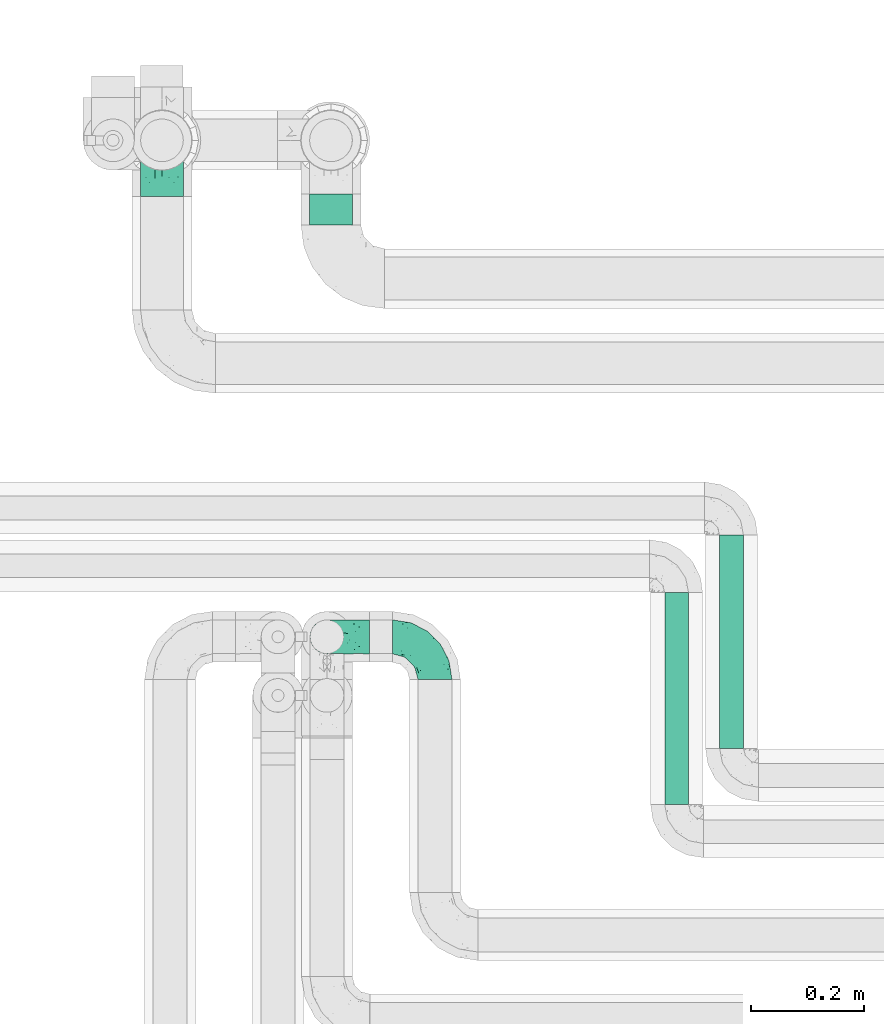
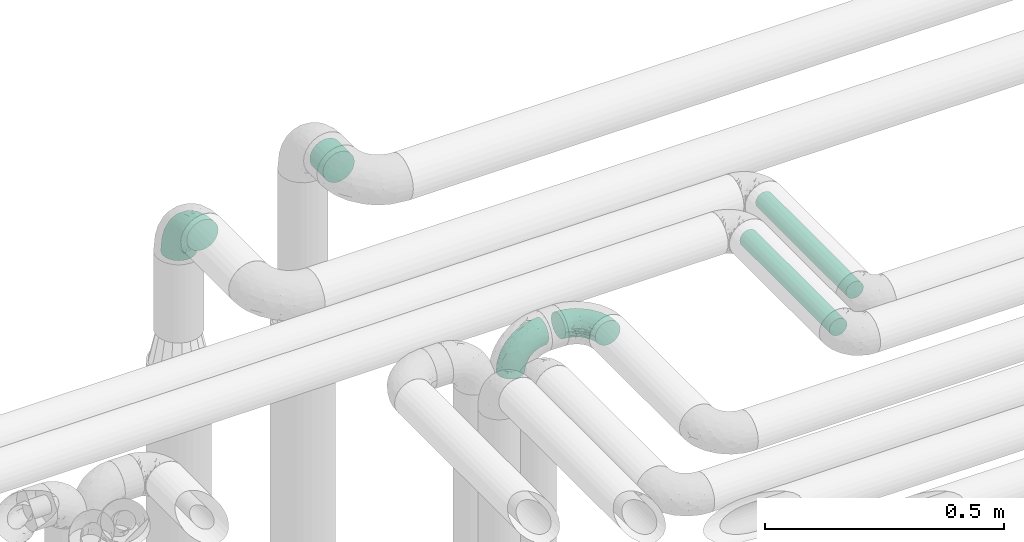
# One storey, part 643 of 827: 3 flow fittings, 3 flow segments.
"""IFC2X3 building model written with IfcOpenShell, lengths in millimetres."""

from ifc_helpers import new_model, entity, si_unit, converted_unit, derived_unit, direction, frame, origin, origin_2d_with_axis, place, context, subcontext, project, spatial, circle, extrude, faceted_brep, source, transform, mapped, material, type_object, type_shapes, element, save


model = new_model("IFC2X3")

# Units and contexts
model_context = context("Model", 3, precision=0.01, world=origin(), true_north=direction((6.12303176911189e-17, 1.0)))
body_context = subcontext(model_context, "Body", "Model", "MODEL_VIEW")
ifc_project = project(units=[si_unit("LENGTHUNIT", "METRE", prefix="MILLI"), si_unit("AREAUNIT", "SQUARE_METRE"), si_unit("VOLUMEUNIT", "CUBIC_METRE"), converted_unit("PLANEANGLEUNIT", "DEGREE", entity("IfcRatioMeasure", 0.0174532925199433), si_unit("PLANEANGLEUNIT", "RADIAN"), dimensions=[0, 0, 0, 0, 0, 0, 0]), si_unit("MASSUNIT", "GRAM", prefix="KILO"), derived_unit("MASSDENSITYUNIT", [(si_unit("MASSUNIT", "GRAM", prefix="KILO"), 1), (si_unit("LENGTHUNIT", "METRE"), -3)]), derived_unit("MOMENTOFINERTIAUNIT", [(si_unit("LENGTHUNIT", "METRE"), 4)]), si_unit("TIMEUNIT", "SECOND"), si_unit("FREQUENCYUNIT", "HERTZ"), si_unit("THERMODYNAMICTEMPERATUREUNIT", "DEGREE_CELSIUS"), derived_unit("THERMALTRANSMITTANCEUNIT", [(si_unit("MASSUNIT", "GRAM", prefix="KILO"), 1), (si_unit("THERMODYNAMICTEMPERATUREUNIT", "KELVIN"), -1), (si_unit("TIMEUNIT", "SECOND"), -3)]), derived_unit("VOLUMETRICFLOWRATEUNIT", [(si_unit("LENGTHUNIT", "METRE"), 3), (si_unit("TIMEUNIT", "SECOND"), -1)]), derived_unit("MASSFLOWRATEUNIT", [(si_unit("MASSUNIT", "GRAM", prefix="KILO"), 1), (si_unit("TIMEUNIT", "SECOND"), -1)]), derived_unit("ROTATIONALFREQUENCYUNIT", [(si_unit("TIMEUNIT", "SECOND"), -1)]), si_unit("ELECTRICCURRENTUNIT", "AMPERE"), si_unit("ELECTRICVOLTAGEUNIT", "VOLT"), si_unit("POWERUNIT", "WATT"), si_unit("FORCEUNIT", "NEWTON", prefix="KILO"), si_unit("ILLUMINANCEUNIT", "LUX"), si_unit("LUMINOUSFLUXUNIT", "LUMEN"), si_unit("LUMINOUSINTENSITYUNIT", "CANDELA"), derived_unit("USERDEFINED", [(si_unit("MASSUNIT", "GRAM", prefix="KILO"), -1), (si_unit("LENGTHUNIT", "METRE"), -2), (si_unit("TIMEUNIT", "SECOND"), 3), (si_unit("LUMINOUSFLUXUNIT", "LUMEN"), 1)]), derived_unit("LINEARVELOCITYUNIT", [(si_unit("LENGTHUNIT", "METRE"), 1), (si_unit("TIMEUNIT", "SECOND"), -1)]), si_unit("PRESSUREUNIT", "PASCAL"), derived_unit("USERDEFINED", [(si_unit("LENGTHUNIT", "METRE"), -2), (si_unit("MASSUNIT", "GRAM", prefix="KILO"), 1), (si_unit("TIMEUNIT", "SECOND"), -2)]), derived_unit("LINEARFORCEUNIT", [(si_unit("MASSUNIT", "GRAM", prefix="KILO"), 1), (si_unit("LENGTHUNIT", "METRE"), 1), (si_unit("TIMEUNIT", "SECOND"), -2), (si_unit("LENGTHUNIT", "METRE"), -1)]), derived_unit("PLANARFORCEUNIT", [(si_unit("MASSUNIT", "GRAM", prefix="KILO"), 1), (si_unit("LENGTHUNIT", "METRE"), 1), (si_unit("TIMEUNIT", "SECOND"), -2), (si_unit("LENGTHUNIT", "METRE"), -2)])], contexts=[model_context])

# Site, building, storey
site_placement = place(None, origin())
site = spatial("IfcSite", under=ifc_project, at=site_placement, CompositionType="ELEMENT")
building_placement = place(site_placement, origin())
building = spatial("IfcBuilding", under=site, at=building_placement, CompositionType="ELEMENT")
storey_placement = place(building_placement, frame((0.0, 0.0, 28200.0)))
storey = spatial("IfcBuildingStorey", under=building, at=storey_placement, Name="08", CompositionType="ELEMENT", Elevation=28200.0)

# Flow segments
pipe_segment_type_1 = type_object("IfcPipeSegmentType", PredefinedType="NOTDEFINED")
flow_segment_1_placement = place(storey_placement, frame((31716.11, 19202.72, 2960.4)))
element("IfcFlowSegment", 1, at=flow_segment_1_placement, inside=storey, type_object=pipe_segment_type_1, context=body_context, shape_type="SweptSolid", body=[
    extrude(circle(Radius=38.0, at=origin_2d_with_axis()), frame((39.6, 0.0, 39.6), z_axis=(0.0, 1.0, 0.0), x_axis=(1.0, 0.0, 0.0)), (0.0, 0.0, 1.0), 55.7170496217003),
])
pipe_segment_type_2 = type_object("IfcPipeSegmentType", PredefinedType="NOTDEFINED")
flow_segment_2_placement = place(storey_placement, frame((32347.29, 18172.91, 2976.76)))
element("IfcFlowSegment", 2, at=flow_segment_2_placement, inside=storey, type_object=pipe_segment_type_2, context=body_context, shape_type="SweptSolid", body=[
    extrude(circle(Radius=21.15, at=origin_2d_with_axis()), frame((22.75, 0.0, 22.75), z_axis=(0.0, 1.0, 0.0), x_axis=(-1.0, 0.0, 0.0)), (0.0, 0.0, 1.0), 376.59487649053),
])
flow_segment_3_placement = place(storey_placement, frame((32444.78, 18272.95, 2977.16)))
element("IfcFlowSegment", 3, at=flow_segment_3_placement, inside=storey, type_object=pipe_segment_type_2, context=body_context, shape_type="SweptSolid", body=[
    extrude(circle(Radius=21.15, at=origin_2d_with_axis()), frame((22.75, 0.0, 22.75), z_axis=(0.0, 1.0, 0.0), x_axis=(-1.0, 0.0, 0.0)), (0.0, 0.0, 1.0), 379.054374559309),
])

# Flow fittings
ifc_material = material()
pipe_fitting_type_1 = type_object("IfcPipeFittingType", Name="ADSK_2", PredefinedType="NOTDEFINED", material=ifc_material)
shared_shape_1 = source(origin(), body_context, "Body", "Brep", [
    faceted_brep([(-100.0, 19.0, -32.91), (-100.0, 9.84, -36.71), (-100.0, 0.0, -38.0), (-100.0, -9.84, -36.71), (-100.0, -19.0, -32.91), (-100.0, -26.87, -26.87), (-100.0, -32.91, -19.0), (-100.0, -36.71, -9.84), (-100.0, -38.0, 0.0), (-100.0, -36.71, 9.84), (-100.0, -32.91, 19.0), (-100.0, -26.87, 26.87), (-100.0, -19.0, 32.91), (-100.0, -9.84, 36.71), (-100.0, 0.0, 38.0), (-100.0, 9.84, 36.71), (-100.0, 19.0, 32.91), (-100.0, 26.87, 26.87), (-100.0, 32.91, 19.0), (-100.0, 36.71, 9.84), (-100.0, 38.0, 0.0), (-100.0, 36.71, -9.84), (-100.0, 32.91, -19.0), (-100.0, 26.87, -26.87), (0.0, 100.0, -38.0), (-9.84, 100.0, -36.71), (-19.0, 100.0, -32.91), (-26.87, 100.0, -26.87), (-32.91, 100.0, -19.0), (-36.71, 100.0, -9.84), (-38.0, 100.0, 0.0), (-36.71, 100.0, 9.84), (-32.91, 100.0, 19.0), (-26.87, 100.0, 26.87), (-19.0, 100.0, 32.91), (-9.84, 100.0, 36.71), (0.0, 100.0, 38.0), (9.84, 100.0, 36.71), (19.0, 100.0, 32.91), (26.87, 100.0, 26.87), (32.91, 100.0, 19.0), (36.71, 100.0, 9.84), (38.0, 100.0, 0.0), (36.71, 100.0, -9.84), (32.91, 100.0, -19.0), (26.87, 100.0, -26.87), (19.0, 100.0, -32.91), (9.84, 100.0, -36.71), (-40.69, 71.44, 16.62), (-81.22, -35.53, 0.0), (-67.52, -31.95, 12.5), (-8.97, -2.95, 6.59), (-11.71, -2.76, 13.62), (-24.68, -14.61, 8.04), (-64.28, -33.3, 0.0), (-83.72, 23.85, 30.89), (-76.19, 33.07, 24.6), (-74.13, -28.58, 21.76), (13.92, 43.47, 26.56), (5.03, 42.28, 32.41), (2.17, 22.78, 25.61), (20.11, 65.77, 28.71), (-65.77, -20.11, 28.71), (-74.23, -13.22, 34.41), (-44.44, -24.14, 12.16), (-47.64, -26.4, 0.0), (-31.0, -19.51, 0.0), (-54.86, 48.59, 21.12), (-81.56, 37.18, 15.86), (-42.28, -5.03, 32.41), (-52.67, 2.67, 37.1), (-14.76, 85.65, 35.5), (-6.46, 75.04, 37.87), (-58.38, 40.19, 26.6), (-15.88, 37.27, 37.68), (-29.21, 13.39, 36.1), (-10.53, 30.95, 35.7), (-77.78, -4.12, 37.45), (-2.67, 52.67, 37.1), (-76.41, 41.64, 8.45), (-71.15, 7.29, 37.89), (-32.26, 79.13, 24.41), (-44.28, 53.84, 26.08), (-25.18, 76.9, 31.2), (19.6, 43.38, 19.97), (6.25, 18.29, 16.9), (19.92, 34.73, 10.46), (-60.8, 50.97, 7.63), (-76.27, 42.72, 0.0), (-77.34, 15.98, 35.72), (-15.11, 15.11, 32.27), (-22.78, -2.17, 25.61), (28.58, 74.13, 21.76), (31.95, 67.52, 12.5), (-51.02, 30.39, 34.96), (-54.69, 20.06, 37.12), (26.4, 47.64, 0.0), (-51.15, 12.85, 38.0), (-32.84, 22.95, 37.94), (4.12, 77.78, 37.45), (-43.38, -19.6, 19.97), (35.53, 81.22, 0.0), (13.22, 74.23, 34.41), (-39.82, 82.33, 7.34), (-42.72, 76.27, 0.0), (-33.83, 52.47, 33.18), (-48.09, 40.81, 31.48), (-56.16, 56.16, 0.0), (-48.2, 64.18, 8.55), (-18.69, 66.93, 35.98), (-49.98, 57.58, 16.12), (-62.54, 46.99, 14.59), (-43.26, -12.84, 27.42), (-17.52, 48.72, 37.89), (-64.19, 29.4, 31.78), (-27.05, 50.9, 36.03), (-36.14, 36.14, 36.75), (-23.99, -8.71, 19.44), (6.3, 13.34, 7.98), (19.51, 31.0, 0.0), (-7.64, 6.3, 21.15), (-16.71, -8.55, 0.0), (33.3, 64.28, 0.0), (-2.42, 2.42, 0.0), (8.55, 16.71, 0.0), (-85.65, 14.76, -35.5), (-23.85, 83.72, -30.89), (-33.07, 76.19, -24.6), (-75.04, 6.46, -37.87), (-37.27, 15.88, -37.68), (-13.39, 29.21, -36.1), (-30.95, 10.53, -35.7), (-79.13, 32.26, -24.41), (-76.9, 25.18, -31.2), (6.3, 13.34, -7.98), (-11.71, -2.76, -13.62), (6.25, 18.29, -16.9), (-82.33, 39.82, -7.34), (-66.93, 18.69, -35.98), (-48.72, 17.52, -37.89), (-64.18, 48.2, -8.55), (31.95, 67.52, -12.5), (28.58, 74.13, -21.76), (-52.47, 33.83, -33.18), (4.12, 77.78, -37.45), (-7.29, 71.15, -37.89), (-15.98, 77.34, -35.72), (-67.52, -31.95, -12.5), (-30.39, 51.02, -34.96), (-20.06, 54.69, -37.12), (-48.59, 54.86, -21.12), (-37.18, 81.56, -15.86), (-74.13, -28.58, -21.76), (-29.4, 64.19, -31.78), (-40.81, 48.09, -31.48), (-40.19, 58.38, -26.6), (-65.77, -20.11, -28.71), (-74.23, -13.22, -34.41), (-39.81, -22.62, -10.22), (-77.78, -4.12, -37.45), (-43.38, -19.6, -19.97), (-12.85, 51.15, -38.0), (-22.95, 32.84, -37.94), (-71.44, 40.69, -16.62), (19.6, 43.38, -19.97), (20.11, 65.77, -28.71), (-52.67, 2.67, -37.1), (-53.84, 44.28, -26.08), (-41.64, 76.41, -8.45), (-23.99, -8.71, -19.44), (-43.47, -13.92, -26.56), (-22.78, -2.17, -25.61), (-20.59, -12.11, -6.83), (13.22, 74.23, -34.41), (5.03, 42.28, -32.41), (-2.67, 52.67, -37.1), (19.92, 34.73, -10.46), (-42.28, -5.03, -32.41), (12.84, 43.26, -27.42), (-50.97, 60.8, -7.63), (-57.58, 49.98, -16.12), (-46.99, 62.54, -14.59), (-50.9, 27.05, -36.03), (-36.14, 36.14, -36.75), (-15.11, 15.11, -32.27), (2.17, 22.78, -25.61), (-7.64, 6.3, -21.15), (-6.28, -0.33, -7.3)], [[[0, 1, 2, 3, 4, 5, 6, 7, 8, 9, 10, 11, 12, 13, 14, 15, 16, 17, 18, 19, 20, 21, 22, 23]], [[24, 25, 26, 27, 28, 29, 30, 31, 32, 33, 34, 35, 36, 37, 38, 39, 40, 41, 42, 43, 44, 45, 46, 47]], [[32, 31, 48]], [[49, 50, 9]], [[51, 52, 53]], [[9, 50, 10]], [[54, 50, 49]], [[17, 55, 56]], [[11, 10, 57]], [[58, 59, 60]], [[61, 39, 38]], [[62, 12, 11]], [[62, 63, 12]], [[64, 65, 66]], [[56, 67, 68]], [[63, 69, 70]], [[35, 71, 72]], [[67, 56, 73]], [[74, 75, 76]], [[16, 55, 17]], [[13, 77, 14]], [[76, 78, 74]], [[68, 79, 19]], [[18, 17, 56]], [[14, 77, 80]], [[20, 19, 79]], [[81, 82, 83]], [[84, 85, 86]], [[87, 88, 79]], [[18, 68, 19]], [[15, 89, 16]], [[14, 80, 15]], [[85, 84, 60]], [[90, 69, 91]], [[92, 84, 93]], [[94, 89, 95]], [[86, 96, 93]], [[83, 71, 34]], [[95, 97, 98]], [[37, 36, 99]], [[40, 39, 92]], [[40, 93, 41]], [[66, 53, 64]], [[92, 93, 40]], [[57, 100, 62]], [[93, 101, 41]], [[93, 84, 86]], [[61, 102, 59]], [[34, 33, 83]], [[103, 48, 31]], [[50, 57, 10]], [[104, 103, 30]], [[94, 105, 106]], [[104, 107, 108]], [[12, 63, 13]], [[83, 109, 71]], [[83, 105, 109]], [[33, 81, 83]], [[67, 110, 111]], [[108, 103, 104]], [[112, 69, 62]], [[34, 71, 35]], [[36, 35, 72]], [[109, 113, 72]], [[102, 38, 37]], [[102, 61, 38]], [[114, 106, 73]], [[89, 15, 80]], [[33, 32, 81]], [[115, 105, 116]], [[109, 115, 113]], [[99, 72, 78]], [[111, 87, 79]], [[108, 87, 110]], [[69, 63, 62]], [[77, 63, 70]], [[100, 117, 112]], [[69, 90, 75]], [[99, 102, 37]], [[78, 76, 59]], [[78, 59, 102]], [[59, 90, 60]], [[100, 57, 50]], [[62, 11, 57]], [[39, 61, 92]], [[84, 92, 61]], [[95, 89, 80]], [[55, 89, 114]], [[83, 82, 105]], [[94, 106, 114]], [[98, 113, 116]], [[78, 72, 113]], [[98, 116, 95]], [[98, 70, 75]], [[32, 48, 81]], [[82, 81, 48]], [[91, 112, 117]], [[60, 84, 58]], [[113, 115, 116]], [[118, 119, 86]], [[90, 91, 60]], [[91, 117, 120]], [[72, 99, 36]], [[102, 99, 78]], [[63, 77, 13]], [[80, 77, 70]], [[95, 80, 97]], [[94, 95, 116]], [[56, 68, 18]], [[79, 68, 111]], [[110, 87, 111]], [[79, 88, 20]], [[108, 107, 87]], [[88, 87, 107]], [[120, 60, 91]], [[66, 121, 53]], [[118, 86, 85]], [[122, 93, 96]], [[52, 118, 85]], [[118, 123, 124, 119]], [[48, 103, 108]], [[30, 103, 31]], [[89, 55, 16]], [[56, 55, 114]], [[80, 70, 97]], [[70, 98, 97]], [[105, 94, 116]], [[89, 94, 114]], [[105, 82, 106]], [[73, 106, 82]], [[67, 73, 82]], [[114, 73, 56]], [[110, 82, 48]], [[67, 111, 68]], [[82, 110, 67]], [[108, 110, 48]], [[69, 75, 70]], [[76, 75, 90]], [[59, 76, 90]], [[78, 113, 74]], [[113, 98, 74]], [[75, 74, 98]], [[9, 8, 49]], [[101, 93, 122]], [[101, 42, 41]], [[72, 71, 109]], [[50, 54, 65]], [[117, 53, 52]], [[109, 105, 115]], [[100, 112, 62]], [[91, 69, 112]], [[123, 51, 121]], [[120, 52, 85]], [[52, 120, 117]], [[60, 120, 85]], [[51, 118, 52]], [[100, 64, 117]], [[50, 64, 100]], [[121, 51, 53]], [[118, 51, 123]], [[84, 61, 58]], [[59, 58, 61]], [[86, 119, 96]], [[65, 64, 50]], [[117, 64, 53]], [[125, 1, 0]], [[27, 126, 127]], [[2, 1, 128]], [[129, 130, 131]], [[132, 133, 23]], [[134, 135, 136]], [[88, 137, 20]], [[138, 139, 128]], [[88, 107, 140]], [[141, 142, 44]], [[138, 133, 143]], [[24, 144, 145]], [[146, 25, 145]], [[125, 133, 138]], [[6, 147, 7]], [[148, 146, 149]], [[147, 49, 7]], [[127, 150, 151]], [[147, 6, 152]], [[153, 154, 155]], [[156, 4, 157]], [[140, 137, 88]], [[24, 145, 25]], [[43, 42, 101]], [[65, 147, 158]], [[148, 143, 154]], [[159, 3, 2]], [[147, 152, 160]], [[149, 161, 162]], [[156, 5, 4]], [[137, 163, 21]], [[142, 164, 165]], [[131, 166, 129]], [[28, 151, 29]], [[167, 133, 132]], [[168, 30, 29]], [[169, 170, 171]], [[127, 28, 27]], [[150, 127, 155]], [[135, 172, 158]], [[26, 25, 146]], [[1, 125, 128]], [[22, 21, 163]], [[126, 27, 26]], [[151, 168, 29]], [[24, 47, 144]], [[45, 165, 46]], [[0, 23, 133]], [[173, 174, 175]], [[119, 134, 176]], [[142, 45, 44]], [[173, 46, 165]], [[141, 44, 43]], [[46, 173, 47]], [[141, 101, 122]], [[156, 157, 177]], [[157, 4, 3]], [[101, 141, 43]], [[178, 174, 165]], [[169, 160, 170]], [[6, 5, 152]], [[170, 177, 171]], [[158, 147, 160]], [[104, 168, 179]], [[141, 96, 176]], [[150, 180, 181]], [[23, 22, 132]], [[182, 143, 183]], [[138, 182, 139]], [[159, 128, 166]], [[181, 179, 168]], [[140, 179, 180]], [[159, 157, 3]], [[166, 131, 177]], [[166, 177, 157]], [[177, 184, 171]], [[174, 173, 165]], [[144, 173, 175]], [[178, 164, 185]], [[174, 184, 130]], [[5, 156, 152]], [[160, 152, 156]], [[164, 142, 141]], [[165, 45, 142]], [[149, 146, 145]], [[126, 146, 153]], [[133, 167, 143]], [[148, 154, 153]], [[162, 139, 183]], [[166, 128, 139]], [[162, 183, 149]], [[162, 175, 130]], [[22, 163, 132]], [[167, 132, 163]], [[174, 185, 184]], [[136, 176, 134]], [[185, 136, 186]], [[158, 172, 66]], [[136, 185, 164]], [[171, 184, 185]], [[128, 159, 2]], [[157, 159, 166]], [[173, 144, 47]], [[145, 144, 175]], [[149, 145, 161]], [[148, 149, 183]], [[127, 151, 28]], [[168, 151, 181]], [[180, 179, 181]], [[168, 104, 30]], [[140, 107, 179]], [[104, 179, 107]], [[176, 136, 164]], [[135, 169, 186]], [[141, 176, 164]], [[134, 119, 124, 123]], [[158, 66, 65]], [[187, 172, 135]], [[163, 137, 140]], [[20, 137, 21]], [[146, 126, 26]], [[127, 126, 153]], [[145, 175, 161]], [[175, 162, 161]], [[143, 148, 183]], [[146, 148, 153]], [[143, 167, 154]], [[155, 154, 167]], [[150, 155, 167]], [[153, 155, 127]], [[180, 167, 163]], [[150, 181, 151]], [[167, 180, 150]], [[140, 180, 163]], [[174, 130, 175]], [[131, 130, 184]], [[177, 131, 184]], [[166, 139, 129]], [[139, 162, 129]], [[130, 129, 162]], [[49, 147, 54]], [[49, 8, 7]], [[133, 125, 0]], [[128, 125, 138]], [[158, 160, 169]], [[65, 54, 147]], [[187, 135, 134]], [[187, 121, 172]], [[134, 123, 187]], [[139, 182, 183]], [[121, 187, 123]], [[121, 66, 172]], [[138, 143, 182]], [[160, 156, 170]], [[177, 170, 156]], [[186, 169, 171]], [[158, 169, 135]], [[185, 186, 171]], [[135, 186, 136]], [[164, 178, 165]], [[185, 174, 178]], [[96, 141, 122]], [[96, 119, 176]]]),
])
type_shapes(pipe_fitting_type_1, [shared_shape_1])
flow_fitting_placement = place(storey_placement, frame((31455.41, 19353.43, 2900.08), z_axis=(-1.0, 0.0, 0.0), x_axis=(0.0, 1.0, 0.0)))
element("IfcFlowFitting", 4, at=flow_fitting_placement, inside=storey, type_object=pipe_fitting_type_1, material=ifc_material, Name="ADSK_2", ObjectType="ADSK_2", context=body_context, shape_type="MappedRepresentation", body=[
    mapped(shared_shape_1, transform((0.0, 0.0, 0.0), scale=1.0)),
])
pipe_fitting_type_2 = type_object("IfcPipeFittingType", Name="ADSK_1", PredefinedType="NOTDEFINED", material=ifc_material)
shared_shape_2 = source(origin(), body_context, "Body", "Brep", [
    faceted_brep([(-76.0, 15.07, -26.11), (-76.0, 7.8, -29.12), (-76.0, 0.0, -30.15), (-76.0, -7.8, -29.12), (-76.0, -15.08, -26.11), (-76.0, -21.32, -21.32), (-76.0, -26.11, -15.08), (-76.0, -29.12, -7.8), (-76.0, -30.15, 0.0), (-76.0, -29.12, 7.8), (-76.0, -26.11, 15.07), (-76.0, -21.32, 21.32), (-76.0, -15.08, 26.11), (-76.0, -7.8, 29.12), (-76.0, 0.0, 30.15), (-76.0, 7.8, 29.12), (-76.0, 15.07, 26.11), (-76.0, 21.32, 21.32), (-76.0, 26.11, 15.07), (-76.0, 29.12, 7.8), (-76.0, 30.15, 0.0), (-76.0, 29.12, -7.8), (-76.0, 26.11, -15.08), (-76.0, 21.32, -21.32), (0.0, 76.0, -30.15), (-7.8, 76.0, -29.12), (-15.07, 76.0, -26.11), (-21.32, 76.0, -21.32), (-26.11, 76.0, -15.08), (-29.12, 76.0, -7.8), (-30.15, 76.0, 0.0), (-29.12, 76.0, 7.8), (-26.11, 76.0, 15.07), (-21.32, 76.0, 21.32), (-15.07, 76.0, 26.11), (-7.8, 76.0, 29.12), (0.0, 76.0, 30.15), (7.8, 76.0, 29.12), (15.08, 76.0, 26.11), (21.32, 76.0, 21.32), (26.11, 76.0, 15.07), (29.12, 76.0, 7.8), (30.15, 76.0, 0.0), (29.12, 76.0, -7.8), (26.11, 76.0, -15.08), (21.32, 76.0, -21.32), (15.08, 76.0, -26.11), (7.8, 76.0, -29.12), (10.79, 31.43, 21.07), (4.32, 31.7, 25.72), (1.65, 15.19, 19.92), (-61.17, -27.8, 0.0), (-51.1, -25.49, 9.84), (-56.14, -10.61, 27.27), (-31.7, -4.32, 25.72), (-39.75, 1.72, 29.41), (-43.2, -24.95, 0.0), (-1.86, 1.86, 0.0), (4.49, 7.65, 5.78), (-7.82, -4.61, 5.83), (-56.21, -22.79, 17.21), (-58.98, -3.38, 29.7), (-53.96, 5.6, 30.07), (-10.86, 10.86, 25.48), (-17.2, -2.6, 20.44), (-49.15, -16.01, 22.7), (-22.18, -14.24, 7.99), (-28.4, -17.42, 0.0), (-13.61, -9.88, 0.0), (-39.0, 23.48, 27.76), (-58.76, 12.54, 28.36), (-41.61, 15.41, 29.48), (16.01, 49.15, 22.7), (-58.55, 25.93, 19.53), (-51.53, 33.5, 13.51), (-64.92, 28.76, 12.4), (-7.48, 23.14, 28.25), (-1.72, 39.75, 29.41), (-12.04, 27.88, 29.88), (-63.91, 18.81, 24.52), (-11.63, 65.16, 28.18), (-4.97, 57.02, 30.05), (9.88, 13.61, 0.0), (-62.5, 31.74, 5.02), (-45.17, 30.98, 21.2), (-21.78, 9.76, 28.58), (10.61, 56.14, 27.27), (-32.09, 54.42, 13.26), (22.79, 56.21, 17.21), (15.38, 31.17, 15.63), (25.49, 51.1, 9.84), (21.84, 36.35, 5.92), (24.95, 43.2, 0.0), (3.38, 58.98, 29.7), (-31.17, -15.38, 15.63), (-39.39, 41.78, 15.45), (-34.56, 41.13, 20.79), (-39.81, -23.25, 5.49), (27.8, 61.17, 0.0), (-31.74, 62.5, 5.02), (-53.07, 36.29, 0.0), (-42.95, 42.95, 7.29), (-36.29, 53.07, 0.0), (-19.83, 58.51, 24.79), (-25.48, 60.2, 19.41), (-14.53, 50.96, 28.57), (-13.31, 37.09, 30.07), (-26.16, 40.06, 26.4), (-32.43, -10.35, 21.9), (17.42, 28.4, 0.0), (14.24, 22.18, 7.99), (-38.67, 9.72, 30.15), (-24.66, 17.36, 30.09), (-37.08, 31.49, 24.99), (-49.27, 22.83, 25.24), (-20.8, 38.81, 28.63), (-27.58, 27.58, 29.2), (-36.07, -20.23, 10.71), (-15.19, -6.16, 14.9), (6.6, 15.4, 14.49), (-2.51, 2.51, 11.35), (-65.16, 11.63, -28.18), (-49.15, -16.01, -22.7), (-57.02, 4.97, -30.05), (-25.93, 58.55, -19.53), (-33.5, 51.53, -13.51), (-28.76, 64.92, -12.4), (-60.2, 25.48, -19.41), (-58.51, 19.83, -24.79), (4.61, 7.82, -5.83), (-7.65, -4.49, -5.78), (-2.51, 2.51, -11.35), (-62.5, 31.74, -5.02), (-50.96, 14.53, -28.57), (-37.09, 13.31, -30.07), (-42.95, 42.95, -7.29), (25.49, 51.1, -9.84), (22.79, 56.21, -17.21), (-40.06, 26.16, -26.4), (3.38, 58.98, -29.7), (-5.6, 53.96, -30.07), (-27.88, 12.04, -29.88), (-9.76, 21.78, -28.58), (-23.14, 7.48, -28.25), (-51.1, -25.49, -9.84), (15.38, 31.17, -15.63), (16.01, 49.15, -22.7), (-23.48, 39.0, -27.76), (-12.54, 58.76, -28.36), (-15.41, 41.61, -29.48), (-56.21, -22.79, -17.21), (-9.72, 38.67, -30.15), (-17.36, 24.66, -30.09), (-22.18, -14.24, -7.99), (-41.13, 34.56, -20.79), (-31.74, 62.5, -5.02), (-58.98, -3.38, -29.7), (-31.17, -15.38, -15.63), (-56.14, -10.61, -27.27), (14.24, 22.18, -7.99), (23.25, 39.81, -5.49), (-31.49, 37.08, -24.99), (-15.19, -6.16, -14.9), (1.65, 15.19, -19.92), (-18.81, 63.91, -24.52), (-32.59, -11.62, -20.84), (-31.7, -4.32, -25.72), (-17.2, -2.6, -20.44), (-39.75, 1.72, -29.41), (-54.42, 32.09, -13.26), (-30.98, 45.17, -21.2), (10.61, 56.14, -27.27), (10.23, 31.31, -21.52), (4.32, 31.7, -25.72), (-41.78, 39.39, -15.45), (-1.72, 39.75, -29.41), (-36.35, -21.84, -5.92), (-22.83, 49.27, -25.24), (-38.81, 20.8, -28.63), (-27.58, 27.58, -29.2), (-10.86, 10.86, -25.48), (20.23, 36.07, -10.71), (6.6, 15.4, -14.49)], [[[0, 1, 2, 3, 4, 5, 6, 7, 8, 9, 10, 11, 12, 13, 14, 15, 16, 17, 18, 19, 20, 21, 22, 23]], [[24, 25, 26, 27, 28, 29, 30, 31, 32, 33, 34, 35, 36, 37, 38, 39, 40, 41, 42, 43, 44, 45, 46, 47]], [[48, 49, 50]], [[51, 52, 9]], [[53, 54, 55]], [[9, 52, 10]], [[56, 52, 51]], [[57, 58, 59]], [[11, 10, 60]], [[14, 61, 62]], [[63, 54, 64]], [[65, 12, 11]], [[65, 53, 12]], [[66, 67, 68]], [[69, 70, 71]], [[72, 39, 38]], [[73, 74, 75]], [[15, 70, 16]], [[76, 77, 78]], [[16, 79, 17]], [[13, 61, 14]], [[35, 80, 81]], [[14, 62, 15]], [[17, 73, 18]], [[57, 82, 58]], [[20, 19, 83]], [[75, 19, 18]], [[70, 15, 62]], [[73, 84, 74]], [[78, 85, 76]], [[38, 86, 72]], [[32, 31, 87]], [[88, 89, 90]], [[91, 92, 90]], [[72, 86, 49]], [[36, 93, 37]], [[75, 83, 19]], [[36, 35, 81]], [[60, 94, 65]], [[40, 90, 41]], [[95, 96, 87]], [[88, 90, 40]], [[66, 97, 67]], [[90, 98, 41]], [[40, 39, 88]], [[99, 31, 30]], [[20, 83, 100]], [[101, 102, 100]], [[52, 60, 10]], [[102, 99, 30]], [[96, 103, 104]], [[83, 101, 100]], [[12, 53, 13]], [[104, 103, 33]], [[105, 106, 81]], [[107, 105, 103]], [[64, 54, 108]], [[80, 103, 105]], [[80, 35, 34]], [[34, 33, 103]], [[86, 38, 37]], [[109, 110, 82]], [[71, 111, 112]], [[69, 107, 113]], [[79, 73, 17]], [[114, 113, 84]], [[33, 32, 104]], [[115, 107, 116]], [[105, 115, 106]], [[93, 81, 77]], [[54, 53, 65]], [[61, 53, 55]], [[108, 94, 64]], [[54, 63, 85]], [[93, 86, 37]], [[77, 76, 49]], [[77, 49, 86]], [[49, 63, 50]], [[60, 52, 117]], [[65, 11, 60]], [[39, 72, 88]], [[89, 88, 72]], [[71, 70, 62]], [[79, 70, 114]], [[103, 96, 107]], [[69, 113, 114]], [[112, 106, 116]], [[77, 81, 106]], [[112, 116, 71]], [[112, 55, 85]], [[64, 50, 63]], [[57, 59, 68]], [[32, 87, 104]], [[96, 104, 87]], [[94, 118, 64]], [[50, 119, 89]], [[50, 64, 118]], [[50, 89, 48]], [[81, 93, 36]], [[86, 93, 77]], [[53, 61, 13]], [[62, 61, 55]], [[71, 62, 111]], [[69, 71, 116]], [[95, 101, 74]], [[99, 101, 87]], [[118, 66, 59]], [[117, 97, 66]], [[117, 66, 94]], [[91, 89, 110]], [[91, 110, 109]], [[110, 89, 119]], [[9, 8, 51]], [[98, 90, 92]], [[98, 42, 41]], [[101, 83, 74]], [[101, 99, 102]], [[87, 31, 99]], [[62, 55, 111]], [[55, 112, 111]], [[107, 69, 116]], [[70, 69, 114]], [[107, 96, 113]], [[84, 113, 96]], [[84, 96, 95]], [[114, 84, 73]], [[70, 79, 16]], [[73, 79, 114]], [[54, 85, 55]], [[76, 85, 63]], [[49, 76, 63]], [[77, 106, 78]], [[106, 112, 78]], [[85, 78, 112]], [[73, 75, 18]], [[83, 75, 74]], [[103, 80, 34]], [[81, 80, 105]], [[101, 95, 87]], [[84, 95, 74]], [[106, 115, 116]], [[105, 107, 115]], [[120, 59, 58]], [[82, 110, 58]], [[119, 58, 110]], [[118, 59, 120]], [[66, 68, 59]], [[54, 65, 108]], [[94, 108, 65]], [[66, 118, 94]], [[50, 118, 120]], [[50, 120, 119]], [[119, 120, 58]], [[89, 72, 48]], [[49, 48, 72]], [[60, 117, 94]], [[117, 52, 97]], [[52, 56, 97]], [[67, 97, 56]], [[92, 91, 109]], [[89, 91, 90]], [[121, 1, 0]], [[122, 5, 4]], [[2, 1, 123]], [[124, 125, 126]], [[127, 128, 23]], [[129, 130, 131]], [[100, 132, 20]], [[133, 134, 123]], [[135, 100, 102]], [[136, 137, 44]], [[133, 128, 138]], [[24, 139, 140]], [[141, 142, 143]], [[121, 128, 133]], [[6, 144, 7]], [[137, 145, 146]], [[144, 51, 7]], [[147, 148, 149]], [[144, 6, 150]], [[149, 151, 152]], [[153, 68, 67]], [[154, 128, 127]], [[30, 155, 102]], [[43, 42, 98]], [[156, 3, 2]], [[157, 144, 150]], [[158, 4, 3]], [[24, 140, 25]], [[155, 135, 102]], [[159, 160, 109]], [[30, 29, 155]], [[147, 138, 161]], [[27, 124, 28]], [[57, 129, 82]], [[162, 163, 131]], [[27, 26, 164]], [[148, 26, 25]], [[165, 166, 167]], [[24, 47, 139]], [[143, 168, 141]], [[22, 21, 169]], [[125, 124, 170]], [[148, 25, 140]], [[46, 146, 171]], [[158, 122, 4]], [[0, 23, 128]], [[1, 121, 123]], [[109, 82, 159]], [[45, 44, 137]], [[146, 46, 45]], [[136, 43, 98]], [[132, 21, 20]], [[136, 98, 92]], [[172, 173, 146]], [[46, 171, 47]], [[43, 136, 44]], [[174, 154, 169]], [[171, 173, 175]], [[6, 5, 150]], [[126, 29, 28]], [[176, 56, 144]], [[122, 158, 166]], [[164, 124, 27]], [[177, 161, 170]], [[23, 22, 127]], [[178, 138, 179]], [[133, 178, 134]], [[156, 123, 168]], [[156, 158, 3]], [[168, 143, 166]], [[168, 166, 158]], [[166, 180, 167]], [[173, 171, 146]], [[139, 171, 175]], [[172, 145, 163]], [[173, 180, 142]], [[5, 122, 150]], [[157, 150, 122]], [[137, 136, 181]], [[146, 45, 137]], [[149, 148, 140]], [[164, 148, 177]], [[128, 154, 138]], [[147, 161, 177]], [[152, 134, 179]], [[168, 123, 134]], [[152, 179, 149]], [[152, 175, 142]], [[57, 130, 129]], [[157, 165, 167]], [[22, 169, 127]], [[154, 127, 169]], [[163, 167, 180]], [[162, 157, 167]], [[173, 163, 180]], [[182, 163, 145]], [[123, 156, 2]], [[158, 156, 168]], [[171, 139, 47]], [[140, 139, 175]], [[149, 140, 151]], [[147, 149, 179]], [[174, 135, 125]], [[132, 135, 169]], [[176, 157, 153]], [[176, 153, 67]], [[153, 157, 162]], [[182, 159, 129]], [[181, 160, 159]], [[181, 159, 145]], [[51, 144, 56]], [[51, 8, 7]], [[135, 132, 100]], [[169, 21, 132]], [[126, 155, 29]], [[135, 155, 125]], [[140, 175, 151]], [[175, 152, 151]], [[138, 147, 179]], [[148, 147, 177]], [[138, 154, 161]], [[170, 161, 154]], [[170, 154, 174]], [[177, 170, 124]], [[148, 164, 26]], [[124, 164, 177]], [[173, 142, 175]], [[143, 142, 180]], [[166, 143, 180]], [[168, 134, 141]], [[134, 152, 141]], [[142, 141, 152]], [[124, 126, 28]], [[155, 126, 125]], [[128, 121, 0]], [[123, 121, 133]], [[135, 174, 169]], [[170, 174, 125]], [[134, 178, 179]], [[133, 138, 178]], [[130, 153, 162]], [[68, 153, 130]], [[57, 68, 130]], [[182, 129, 131]], [[159, 82, 129]], [[157, 122, 165]], [[166, 165, 122]], [[163, 162, 167]], [[162, 131, 130]], [[145, 172, 146]], [[163, 173, 172]], [[159, 182, 145]], [[131, 163, 182]], [[56, 176, 67]], [[157, 176, 144]], [[137, 181, 145]], [[181, 136, 160]], [[136, 92, 160]], [[109, 160, 92]]]),
])
type_shapes(pipe_fitting_type_2, [shared_shape_2])
for number, where, z_axis, x_axis, name in (
    (5, (31940.66, 18471.2, 3000.0), (0.0, 0.0, 1.0), (0.0, 1.0, 0.0), "ADSK_1"),
    (6, (31748.66, 18471.2, 3000.0), (0.0, -1.0, 0.0), (-1.0, 0.0, 0.0), "ADSK_1"),
):
    element("IfcFlowFitting", number, at=place(storey_placement, frame(where, z_axis=z_axis, x_axis=x_axis)), inside=storey, type_object=pipe_fitting_type_2, material=ifc_material, Name=name, ObjectType="ADSK_1", context=body_context, shape_type="MappedRepresentation", body=[
        mapped(shared_shape_2, transform((0.0, 0.0, 0.0), scale=1.0)),
    ])

save(model, "model.ifc")
